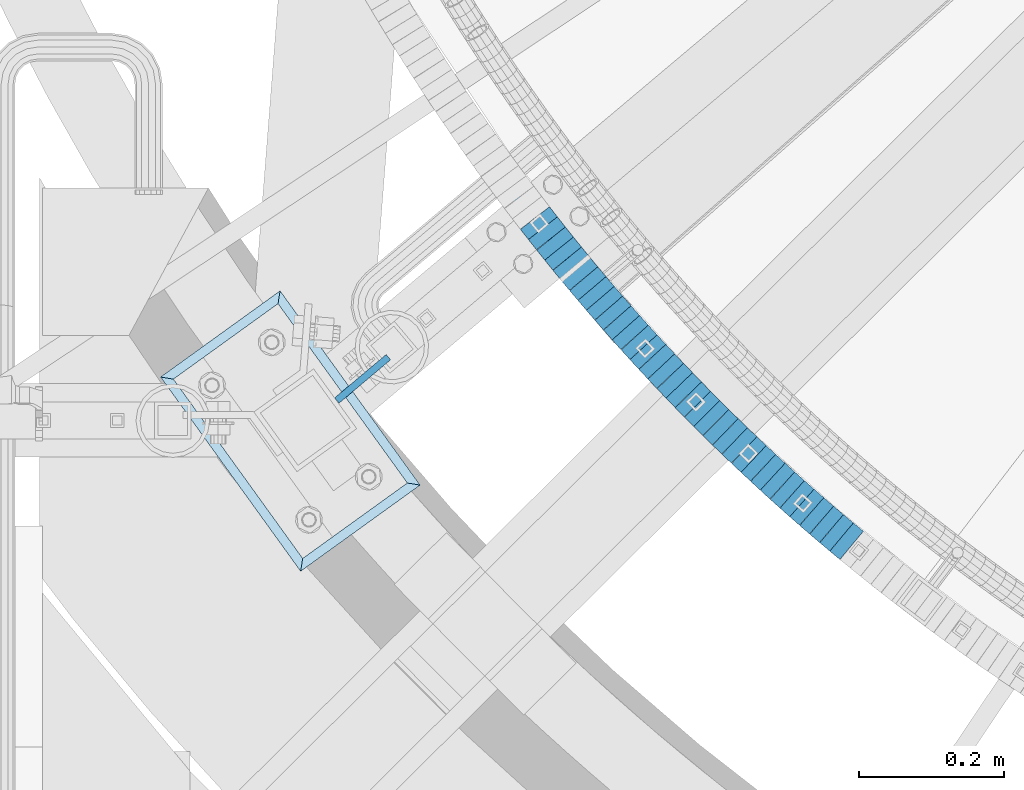
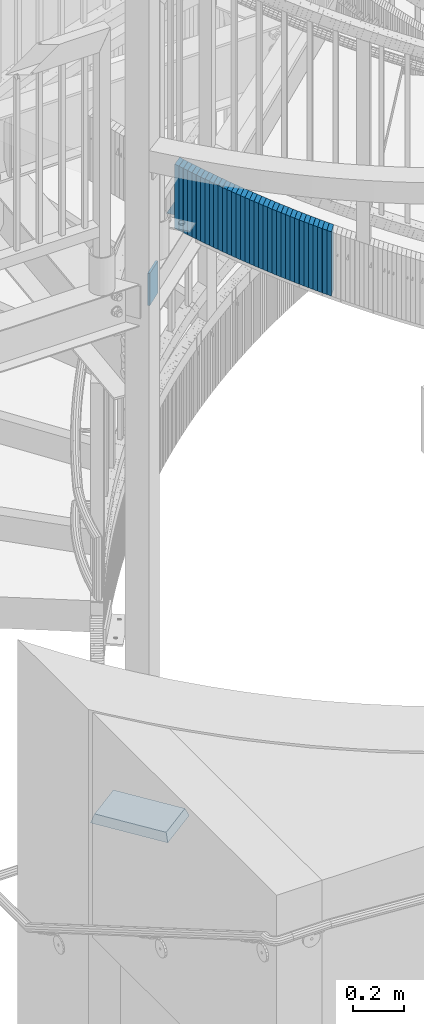
# One storey, part 875 of 975: 38 plates.
"""IFC2X3 building model written with IfcOpenShell, lengths in millimetres."""

from ifc_helpers import new_model, si_unit, frame, origin_with_axes, place, context, subcontext, project, spatial, faceted_brep, material, type_object, element, save


model = new_model("IFC2X3")

# Units and contexts
model_context = context("Model", 3, precision=1e-05, world=origin_with_axes())
body_context = subcontext(model_context, "Body", "Model", "MODEL_VIEW")
ifc_project = project(units=[si_unit("LENGTHUNIT", "METRE", prefix="MILLI"), si_unit("AREAUNIT", "SQUARE_METRE"), si_unit("VOLUMEUNIT", "CUBIC_METRE"), si_unit("MASSUNIT", "GRAM", prefix="KILO"), si_unit("TIMEUNIT", "SECOND"), si_unit("PLANEANGLEUNIT", "RADIAN"), si_unit("SOLIDANGLEUNIT", "STERADIAN"), si_unit("THERMODYNAMICTEMPERATUREUNIT", "DEGREE_CELSIUS"), si_unit("LUMINOUSINTENSITYUNIT", "LUMEN")], contexts=[model_context])

# Site, building, storey
site_placement = place(None, origin_with_axes())
site = spatial("IfcSite", under=ifc_project, at=site_placement, CompositionType="ELEMENT")
building_placement = place(site_placement, origin_with_axes())
building = spatial("IfcBuilding", under=site, at=building_placement, Name="Undefined", CompositionType="ELEMENT")
storey_placement = place(building_placement, origin_with_axes())
storey = spatial("IfcBuildingStorey", under=building, at=storey_placement, Name="Undefined", CompositionType="ELEMENT", Elevation=0.0)

# Plates
ifc_material_1 = material(Name="STEEL/A36")
plate_type_1 = type_object("IfcPlateType", PredefinedType="NOTDEFINED")
plate_1_placement = place(storey_placement, frame((32477.8496089641, 1629.99824004207, 3887.98750006769), z_axis=(-0.614330726999909, 0.789048640999883, 0.0), x_axis=(0.0, 0.0, 1.0)))
element("IfcPlate", 1, at=plate_1_placement, inside=storey, type_object=plate_type_1, material=ifc_material_1, Name="WALL", context=body_context, shape_type="Brep", body=[
    faceted_brep([(0.0, -25.3999999999724, -1.81898940354586e-11), (5.69999980926514, -25.3999999999833, 17.7428855895923), (5.69999980926514, 25.4000000000051, 17.7428855895996), (0.0, 25.3999999999869, 1.45519152283669e-11), (310.5, -25.3999999999833, 17.7428855895923), (310.5, 25.4000000000051, 17.7428855895996), (304.799987792969, -25.3999999999724, -1.81898940354586e-11), (304.799987792969, 25.3999999999869, 1.45519152283669e-11)], [[[0, 1, 2, 3]], [[1, 4, 5, 2]], [[4, 6, 7, 5]], [[6, 0, 3, 7]], [[5, 7, 3, 2]], [[6, 4, 1, 0]]]),
])
plate_2_placement = place(storey_placement, frame((32488.9189586468, 1615.90957309081, 3882.28750006769), z_axis=(-0.61782155188774, 0.786318338857122, 0.0), x_axis=(0.0, 0.0, 1.0)))
element("IfcPlate", 2, at=plate_2_placement, inside=storey, type_object=plate_type_1, material=ifc_material_1, Name="WALL", context=body_context, shape_type="Brep", body=[
    faceted_brep([(0.0, -25.3999999999724, -1.81898940354586e-11), (5.69999980926514, -25.4000000000196, 17.8002815246764), (5.69999980926514, 25.4000000000015, 17.8002815246618), (0.0, 25.3999999999869, 1.45519152283669e-11), (310.5, -25.4000000000196, 17.8002815246764), (310.5, 25.4000000000015, 17.8002815246618), (304.799987792969, -25.3999999999724, -1.81898940354586e-11), (304.799987792969, 25.3999999999869, 1.45519152283669e-11)], [[[0, 1, 2, 3]], [[1, 4, 5, 2]], [[4, 6, 7, 5]], [[6, 0, 3, 7]], [[5, 7, 3, 2]], [[6, 4, 1, 0]]]),
])
plate_3_placement = place(storey_placement, frame((32500.1994228176, 1601.88257092471, 3876.68750006769), z_axis=(-0.626758645080496, 0.779213450100074, 0.0), x_axis=(0.0, 0.0, 1.0)))
element("IfcPlate", 3, at=plate_3_placement, inside=storey, type_object=plate_type_1, material=ifc_material_1, Name="WALL", context=body_context, shape_type="Brep", body=[
    faceted_brep([(0.0, -25.3999999999724, -1.81898940354586e-11), (5.59999990463257, -25.4000000000087, 17.710166931156), (5.59999990463257, 25.399999999976, 17.7101669311705), (0.0, 25.3999999999869, 1.45519152283669e-11), (310.399993896484, -25.4000000000087, 17.710166931156), (310.399993896484, 25.399999999976, 17.7101669311705), (304.799987792969, -25.3999999999724, -1.81898940354586e-11), (304.799987792969, 25.3999999999869, 1.45519152283669e-11)], [[[0, 1, 2, 3]], [[1, 4, 5, 2]], [[4, 6, 7, 5]], [[6, 0, 3, 7]], [[5, 7, 3, 2]], [[6, 4, 1, 0]]]),
])
plate_4_placement = place(storey_placement, frame((32511.2994228141, 1588.08257092594, 3870.98750006769), z_axis=(-0.626758645080496, 0.779213450100074, 0.0), x_axis=(0.0, 0.0, 1.0)))
element("IfcPlate", 4, at=plate_4_placement, inside=storey, type_object=plate_type_1, material=ifc_material_1, Name="WALL", context=body_context, shape_type="Brep", body=[
    faceted_brep([(0.0, -25.3999999999724, -1.81898940354586e-11), (5.69999980926514, -25.3999999999978, 17.7101669311523), (5.69999980926514, 25.3999999999869, 17.7101669311669), (0.0, 25.3999999999869, 1.45519152283669e-11), (310.5, -25.3999999999978, 17.7101669311523), (310.5, 25.3999999999869, 17.7101669311669), (304.799987792969, -25.3999999999724, -1.81898940354586e-11), (304.799987792969, 25.3999999999869, 1.45519152283669e-11)], [[[0, 1, 2, 3]], [[1, 4, 5, 2]], [[4, 6, 7, 5]], [[6, 0, 3, 7]], [[5, 7, 3, 2]], [[6, 4, 1, 0]]]),
])
plate_5_placement = place(storey_placement, frame((32522.6265352931, 1574.22581840772, 3865.28750006769), z_axis=(-0.63293000409189, 0.774209022112401, 0.0), x_axis=(0.0, 0.0, 1.0)))
element("IfcPlate", 5, at=plate_5_placement, inside=storey, type_object=plate_type_1, material=ifc_material_1, Name="WALL", context=body_context, shape_type="Brep", body=[
    faceted_brep([(0.0, -25.3999999999724, -1.81898940354586e-11), (5.69999980926514, -25.3999999999724, 17.6954803466615), (5.69999980926514, 25.3999999999651, 17.6954803467124), (0.0, 25.3999999999869, 1.45519152283669e-11), (310.5, -25.3999999999724, 17.6954803466615), (310.5, 25.3999999999651, 17.6954803467124), (304.799987792969, -25.3999999999724, -1.81898940354586e-11), (304.799987792969, 25.3999999999869, 1.45519152283669e-11)], [[[0, 1, 2, 3]], [[1, 4, 5, 2]], [[4, 6, 7, 5]], [[6, 0, 3, 7]], [[5, 7, 3, 2]], [[6, 4, 1, 0]]]),
])
plate_6_placement = place(storey_placement, frame((32534.0550952989, 1560.46983275219, 3859.58750006769), z_axis=(-0.639071171629759, 0.769147604554397, 0.0), x_axis=(0.0, 0.0, 1.0)))
element("IfcPlate", 6, at=plate_6_placement, inside=storey, type_object=plate_type_1, material=ifc_material_1, Name="WALL", context=body_context, shape_type="Brep", body=[
    faceted_brep([(0.0, -25.3999999999724, -1.81898940354586e-11), (5.69999980926514, -25.4000000000124, 17.6819114685204), (5.69999980926514, 25.3999999999978, 17.6819114685022), (0.0, 25.3999999999869, 1.45519152283669e-11), (310.5, -25.4000000000124, 17.6819114685204), (310.5, 25.3999999999978, 17.6819114685022), (304.799987792969, -25.3999999999724, -1.81898940354586e-11), (304.799987792969, 25.3999999999869, 1.45519152283669e-11)], [[[0, 1, 2, 3]], [[1, 4, 5, 2]], [[4, 6, 7, 5]], [[6, 0, 3, 7]], [[5, 7, 3, 2]], [[6, 4, 1, 0]]]),
])
plate_7_placement = place(storey_placement, frame((32545.5850845881, 1546.81464773903, 3853.98750006769), z_axis=(-0.645180817852216, 0.764029915824993, 0.0), x_axis=(0.0, 0.0, 1.0)))
element("IfcPlate", 7, at=plate_7_placement, inside=storey, type_object=plate_type_1, material=ifc_material_1, Name="WALL", context=body_context, shape_type="Brep", body=[
    faceted_brep([(0.0, -25.3999999999724, -1.81898940354586e-11), (5.59999990463257, -25.4000000000451, 17.6694660187168), (5.59999990463257, 25.4000000000124, 17.6694660186622), (0.0, 25.3999999999869, 1.45519152283669e-11), (310.399993896484, -25.4000000000451, 17.6694660187168), (310.399993896484, 25.4000000000124, 17.6694660186622), (304.799987792969, -25.3999999999724, -1.81898940354586e-11), (304.799987792969, 25.3999999999869, 1.45519152283669e-11)], [[[0, 1, 2, 3]], [[1, 4, 5, 2]], [[4, 6, 7, 5]], [[6, 0, 3, 7]], [[5, 7, 3, 2]], [[6, 4, 1, 0]]]),
])
plate_8_placement = place(storey_placement, frame((32557.0453119958, 1533.34359052794, 3848.28750006769), z_axis=(-0.647978346010379, 0.761658757647842, 7.64916876505595e-11), x_axis=(0.0, 0.0, 1.0)))
element("IfcPlate", 8, at=plate_8_placement, inside=storey, type_object=plate_type_1, material=ifc_material_1, Name="WALL", context=body_context, shape_type="Brep", body=[
    faceted_brep([(0.0, -25.3999999999724, -1.81898940354586e-11), (5.69999980926514, -25.4000000000087, 17.5931797027697), (5.69999980926514, 25.4000000000124, 17.5931797027552), (0.0, 25.3999999999869, 1.45519152283669e-11), (310.5, -25.4000000000087, 17.5931797027697), (310.5, 25.4000000000124, 17.5931797027552), (304.799987792969, -25.3999999999724, -1.81898940354586e-11), (304.799987792969, 25.3999999999869, 1.45519152283669e-11)], [[[0, 1, 2, 3]], [[1, 4, 5, 2]], [[4, 6, 7, 5]], [[6, 0, 3, 7]], [[5, 7, 3, 2]], [[6, 4, 1, 0]]]),
])
plate_9_placement = place(storey_placement, frame((32568.6164840089, 1519.86029685642, 3842.68750006769), z_axis=(-0.651257624283248, 0.758856710330046, 0.0), x_axis=(0.0, 0.0, 1.0)))
element("IfcPlate", 9, at=plate_9_placement, inside=storey, type_object=plate_type_1, material=ifc_material_1, Name="WALL", context=body_context, shape_type="Brep", body=[
    faceted_brep([(0.0, -25.3999999999724, -1.81898940354586e-11), (5.59999990463257, -25.3999999999905, 17.6581420898401), (5.59999990463257, 25.4000000000196, 17.6581420898292), (0.0, 25.3999999999869, 1.45519152283669e-11), (310.399993896484, -25.3999999999905, 17.6581420898401), (310.399993896484, 25.4000000000196, 17.6581420898292), (304.799987792969, -25.3999999999724, -1.81898940354586e-11), (304.799987792969, 25.3999999999869, 1.45519152283669e-11)], [[[0, 1, 2, 3]], [[1, 4, 5, 2]], [[4, 6, 7, 5]], [[6, 0, 3, 7]], [[5, 7, 3, 2]], [[6, 4, 1, 0]]]),
])
plate_10_placement = place(storey_placement, frame((32580.3492735307, 1506.40681323147, 3836.98750006769), z_axis=(-0.657300286732873, 0.753628776693727, 0.0), x_axis=(0.0, 0.0, 1.0)))
element("IfcPlate", 10, at=plate_10_placement, inside=storey, type_object=plate_type_1, material=ifc_material_1, Name="WALL", context=body_context, shape_type="Brep", body=[
    faceted_brep([(0.0, -25.3999999999724, -1.81898940354586e-11), (5.69999980926514, -25.3999999999869, 17.6479454040382), (5.69999980926514, 25.3999999999651, 17.6479454040818), (0.0, 25.3999999999869, 1.45519152283669e-11), (310.5, -25.3999999999869, 17.6479454040382), (310.5, 25.3999999999651, 17.6479454040818), (304.799987792969, -25.3999999999724, -1.81898940354586e-11), (304.799987792969, 25.3999999999869, 1.45519152283669e-11)], [[[0, 1, 2, 3]], [[1, 4, 5, 2]], [[4, 6, 7, 5]], [[6, 0, 3, 7]], [[5, 7, 3, 2]], [[6, 4, 1, 0]]]),
])
plate_11_placement = place(storey_placement, frame((32592.3994301402, 1492.8361979417, 3831.18750006769), z_axis=(-0.66401742416183, 0.74771709918223, 0.0), x_axis=(0.0, 0.0, 1.0)))
element("IfcPlate", 11, at=plate_11_placement, inside=storey, type_object=plate_type_1, material=ifc_material_1, Name="WALL", context=body_context, shape_type="Brep", body=[
    faceted_brep([(0.0, -25.3999999999724, -1.81898940354586e-11), (5.80000019073486, -25.4000000000233, 17.9178676605334), (5.80000019073486, 25.3999999999942, 17.9178676605297), (0.0, 25.3999999999869, 1.45519152283669e-11), (310.600006103516, -25.4000000000233, 17.9178676605334), (310.600006103516, 25.3999999999942, 17.9178676605297), (304.799987792969, -25.3999999999724, -1.81898940354586e-11), (304.799987792969, 25.3999999999869, 1.45519152283669e-11)], [[[0, 1, 2, 3]], [[1, 4, 5, 2]], [[4, 6, 7, 5]], [[6, 0, 3, 7]], [[5, 7, 3, 2]], [[6, 4, 1, 0]]]),
])
plate_12_placement = place(storey_placement, frame((32604.2994301409, 1479.43619794325, 3825.48750006769), z_axis=(-0.66401742416183, 0.74771709918223, 0.0), x_axis=(0.0, 0.0, 1.0)))
element("IfcPlate", 12, at=plate_12_placement, inside=storey, type_object=plate_type_1, material=ifc_material_1, Name="WALL", context=body_context, shape_type="Brep", body=[
    faceted_brep([(0.0, -25.3999999999724, -1.81898940354586e-11), (5.69999980926514, -25.3999999999724, 17.9212169646999), (5.69999980926514, 25.3999999999651, 17.9212169647544), (0.0, 25.3999999999869, 1.45519152283669e-11), (310.5, -25.3999999999724, 17.9212169646999), (310.5, 25.3999999999651, 17.9212169647544), (304.799987792969, -25.3999999999724, -1.81898940354586e-11), (304.799987792969, 25.3999999999869, 1.45519152283669e-11)], [[[0, 1, 2, 3]], [[1, 4, 5, 2]], [[4, 6, 7, 5]], [[6, 0, 3, 7]], [[5, 7, 3, 2]], [[6, 4, 1, 0]]]),
])
plate_13_placement = place(storey_placement, frame((32616.6033599364, 1465.90932151631, 3819.78750006769), z_axis=(-0.672949566999793, 0.739688366999773, 0.0), x_axis=(0.0, 0.0, 1.0)))
element("IfcPlate", 13, at=plate_13_placement, inside=storey, type_object=plate_type_1, material=ifc_material_1, Name="WALL", context=body_context, shape_type="Brep", body=[
    faceted_brep([(0.0, -25.3999999999724, -1.81898940354586e-11), (5.69999980926514, -25.4000000000233, 17.9805450439708), (5.69999980926514, 25.4000000000124, 17.9805450439344), (0.0, 25.3999999999869, 1.45519152283669e-11), (310.5, -25.4000000000233, 17.9805450439708), (310.5, 25.4000000000124, 17.9805450439344), (304.799987792969, -25.3999999999724, -1.81898940354586e-11), (304.799987792969, 25.3999999999869, 1.45519152283669e-11)], [[[0, 1, 2, 3]], [[1, 4, 5, 2]], [[4, 6, 7, 5]], [[6, 0, 3, 7]], [[5, 7, 3, 2]], [[6, 4, 1, 0]]]),
])
plate_14_placement = place(storey_placement, frame((32628.767729298, 1452.6388349455, 3813.98750006769), z_axis=(-0.675724628879611, 0.737154139868665, 0.0), x_axis=(0.0, 0.0, 1.0)))
element("IfcPlate", 14, at=plate_14_placement, inside=storey, type_object=plate_type_1, material=ifc_material_1, Name="WALL", context=body_context, shape_type="Brep", body=[
    faceted_brep([(0.0, -25.3999999999724, -1.81898940354586e-11), (5.80000019073486, -25.3999999999905, 17.9067020416114), (5.80000019073486, 25.399999999976, 17.9067020416369), (0.0, 25.3999999999869, 1.45519152283669e-11), (310.600006103516, -25.3999999999905, 17.9067020416114), (310.600006103516, 25.399999999976, 17.9067020416369), (304.799987792969, -25.3999999999724, -1.81898940354586e-11), (304.799987792969, 25.3999999999869, 1.45519152283669e-11)], [[[0, 1, 2, 3]], [[1, 4, 5, 2]], [[4, 6, 7, 5]], [[6, 0, 3, 7]], [[5, 7, 3, 2]], [[6, 4, 1, 0]]]),
])
plate_15_placement = place(storey_placement, frame((32641.1037778449, 1439.39158916731, 3808.28750006769), z_axis=(-0.68152170678552, 0.7317978977697, 0.0), x_axis=(0.0, 0.0, 1.0)))
element("IfcPlate", 15, at=plate_15_placement, inside=storey, type_object=plate_type_1, material=ifc_material_1, Name="WALL", context=body_context, shape_type="Brep", body=[
    faceted_brep([(0.0, -25.3999999999724, -1.81898940354586e-11), (5.69999980926514, -25.3999999999978, 17.9011173248218), (5.69999980926514, 25.4000000000087, 17.9011173248182), (0.0, 25.3999999999869, 1.45519152283669e-11), (310.5, -25.3999999999978, 17.9011173248218), (310.5, 25.4000000000087, 17.9011173248182), (304.799987792969, -25.3999999999724, -1.81898940354586e-11), (304.799987792969, 25.3999999999869, 1.45519152283669e-11)], [[[0, 1, 2, 3]], [[1, 4, 5, 2]], [[4, 6, 7, 5]], [[6, 0, 3, 7]], [[5, 7, 3, 2]], [[6, 4, 1, 0]]]),
])
plate_16_placement = place(storey_placement, frame((32653.3700878644, 1426.32065973902, 3802.48750006769), z_axis=(-0.684314203948306, 0.729187266944916, 0.0), x_axis=(0.0, 0.0, 1.0)))
element("IfcPlate", 16, at=plate_16_placement, inside=storey, type_object=plate_type_1, material=ifc_material_1, Name="WALL", context=body_context, shape_type="Brep", body=[
    faceted_brep([(0.0, -25.3999999999724, -1.81898940354586e-11), (5.80000019073486, -25.3999999999796, 17.8280677795228), (5.80000019073486, 25.4000000000196, 17.8280677795265), (0.0, 25.3999999999869, 1.45519152283669e-11), (310.600006103516, -25.3999999999796, 17.8280677795228), (310.600006103516, 25.4000000000196, 17.8280677795265), (304.799987792969, -25.3999999999724, -1.81898940354586e-11), (304.799987792969, 25.3999999999869, 1.45519152283669e-11)], [[[0, 1, 2, 3]], [[1, 4, 5, 2]], [[4, 6, 7, 5]], [[6, 0, 3, 7]], [[5, 7, 3, 2]], [[6, 4, 1, 0]]]),
])
for number, where, z_axis, x_axis, name in (
    (17, (32665.9795570647, 1413.20011620637, 3796.78750006769), (-0.692997020245555, 0.720940448255458, 0.0), (0.0, 0.0, 1.0), "WALL"),
    (18, (32678.3795570702, 1400.30011620766, 3791.08750006769), (-0.692997020245555, 0.720940448255458, 0.0), (0.0, 0.0, 1.0), "WALL"),
):
    element("IfcPlate", number, at=place(storey_placement, frame(where, z_axis=z_axis, x_axis=x_axis)), inside=storey, type_object=plate_type_1, material=ifc_material_1, Name=name, context=body_context, shape_type="Brep", body=[
        faceted_brep([(0.0, -25.3999999999724, -1.81898940354586e-11), (5.69999980926514, -25.3999999999614, 17.8921775817616), (5.69999980926514, 25.400000000016, 17.8921775817726), (0.0, 25.3999999999869, 1.45519152283669e-11), (310.5, -25.3999999999614, 17.8921775817616), (310.5, 25.400000000016, 17.8921775817726), (304.799987792969, -25.3999999999724, -1.81898940354586e-11), (304.799987792969, 25.3999999999869, 1.45519152283669e-11)], [[[0, 1, 2, 3]], [[1, 4, 5, 2]], [[4, 6, 7, 5]], [[6, 0, 3, 7]], [[5, 7, 3, 2]], [[6, 4, 1, 0]]]),
    ])
plate_17_placement = place(storey_placement, frame((32691.0192392283, 1387.3559463482, 3785.28750006769), z_axis=(-0.698672998973499, 0.715441150972864, 0.0), x_axis=(0.0, 0.0, 1.0)))
element("IfcPlate", 19, at=plate_17_placement, inside=storey, type_object=plate_type_1, material=ifc_material_1, Name="WALL", context=body_context, shape_type="Brep", body=[
    faceted_brep([(0.0, -25.3999999999724, -1.81898940354586e-11), (5.80000019073486, -25.4000000000451, 17.8891029358201), (5.80000019073486, 25.4000000000087, 17.8891029357856), (0.0, 25.3999999999869, 1.45519152283669e-11), (310.600006103516, -25.4000000000451, 17.8891029358201), (310.600006103516, 25.4000000000087, 17.8891029357856), (304.799987792969, -25.3999999999724, -1.81898940354586e-11), (304.799987792969, 25.3999999999869, 1.45519152283669e-11)], [[[0, 1, 2, 3]], [[1, 4, 5, 2]], [[4, 6, 7, 5]], [[6, 0, 3, 7]], [[5, 7, 3, 2]], [[6, 4, 1, 0]]]),
])
for number, where, z_axis, x_axis, name in (
    (20, (32703.8309322206, 1374.54172828161, 3779.58750006769), (-0.707106781186601, 0.707106781186494, 2.36468622460961e-14), (0.0, 0.0, 1.0), "WALL"),
    (21, (32716.4309322205, 1361.94172828271, 3773.88750006769), (-0.707106781186601, 0.707106781186494, 2.36468622460961e-14), (0.0, 0.0, 1.0), "WALL"),
):
    element("IfcPlate", number, at=place(storey_placement, frame(where, z_axis=z_axis, x_axis=x_axis)), inside=storey, type_object=plate_type_1, material=ifc_material_1, Name=name, context=body_context, shape_type="Brep", body=[
        faceted_brep([(0.0, -25.3999999999724, -1.81898940354586e-11), (5.69999980926514, -25.3999999999432, 17.8213348388126), (5.69999980926514, 25.3999999999905, 17.8213348388708), (0.0, 25.3999999999869, 1.45519152283669e-11), (310.5, -25.3999999999432, 17.8213348388126), (310.5, 25.3999999999905, 17.8213348388708), (304.799987792969, -25.3999999999724, -1.81898940354586e-11), (304.799987792969, 25.3999999999869, 1.45519152283669e-11)], [[[0, 1, 2, 3]], [[1, 4, 5, 2]], [[4, 6, 7, 5]], [[6, 0, 3, 7]], [[5, 7, 3, 2]], [[6, 4, 1, 0]]]),
    ])
plate_18_placement = place(storey_placement, frame((32729.3729059506, 1349.20086805817, 3768.08750006769), z_axis=(-0.712652459353194, 0.701517264347674, 0.0), x_axis=(0.0, 0.0, 1.0)))
element("IfcPlate", 22, at=plate_18_placement, inside=storey, type_object=plate_type_1, material=ifc_material_1, Name="WALL", context=body_context, shape_type="Brep", body=[
    faceted_brep([(0.0, -25.3999999999724, -1.81898940354586e-11), (5.80000019073486, -25.399999999976, 17.9610691070338), (5.80000019073486, 25.4000000000269, 17.9610691070338), (0.0, 25.3999999999869, 1.45519152283669e-11), (310.600006103516, -25.399999999976, 17.9610691070338), (310.600006103516, 25.4000000000269, 17.9610691070338), (304.799987792969, -25.3999999999724, -1.81898940354586e-11), (304.799987792969, 25.3999999999869, 1.45519152283669e-11)], [[[0, 1, 2, 3]], [[1, 4, 5, 2]], [[4, 6, 7, 5]], [[6, 0, 3, 7]], [[5, 7, 3, 2]], [[6, 4, 1, 0]]]),
])
plate_19_placement = place(storey_placement, frame((32742.3182459892, 1336.65893886599, 3762.38750006769), z_axis=(-0.718240222804791, 0.695795215810891, 0.0), x_axis=(0.0, 0.0, 1.0)))
element("IfcPlate", 23, at=plate_19_placement, inside=storey, type_object=plate_type_1, material=ifc_material_1, Name="WALL", context=body_context, shape_type="Brep", body=[
    faceted_brep([(0.0, -25.3999999999724, -1.81898940354586e-11), (5.69999980926514, -25.3999999999432, 17.8213348388126), (5.69999980926514, 25.3999999999905, 17.8213348388708), (0.0, 25.3999999999869, 1.45519152283669e-11), (310.5, -25.3999999999432, 17.8213348388126), (310.5, 25.3999999999905, 17.8213348388708), (304.799987792969, -25.3999999999724, -1.81898940354586e-11), (304.799987792969, 25.3999999999869, 1.45519152283669e-11)], [[[0, 1, 2, 3]], [[1, 4, 5, 2]], [[4, 6, 7, 5]], [[6, 0, 3, 7]], [[5, 7, 3, 2]], [[6, 4, 1, 0]]]),
])
plate_20_placement = place(storey_placement, frame((32755.2893201537, 1324.19035313969, 3756.68750006769), z_axis=(-0.720940448255459, 0.692997020245555, 0.0), x_axis=(0.0, 0.0, 1.0)))
element("IfcPlate", 24, at=plate_20_placement, inside=storey, type_object=plate_type_1, material=ifc_material_1, Name="WALL", context=body_context, shape_type="Brep", body=[
    faceted_brep([(0.0, -25.3999999999724, -1.81898940354586e-11), (5.69999980926514, -25.3999999999614, 17.8921775817616), (5.69999980926514, 25.400000000016, 17.8921775817726), (0.0, 25.3999999999869, 1.45519152283669e-11), (310.5, -25.3999999999614, 17.8921775817616), (310.5, 25.400000000016, 17.8921775817726), (304.799987792969, -25.3999999999724, -1.81898940354586e-11), (304.799987792969, 25.3999999999869, 1.45519152283669e-11)], [[[0, 1, 2, 3]], [[1, 4, 5, 2]], [[4, 6, 7, 5]], [[6, 0, 3, 7]], [[5, 7, 3, 2]], [[6, 4, 1, 0]]]),
])
plate_21_placement = place(storey_placement, frame((32768.5098637013, 1311.78088394523, 3750.98750006769), z_axis=(-0.729187266944916, 0.684314203948306, 0.0), x_axis=(0.0, 0.0, 1.0)))
element("IfcPlate", 25, at=plate_21_placement, inside=storey, type_object=plate_type_1, material=ifc_material_1, Name="WALL", context=body_context, shape_type="Brep", body=[
    faceted_brep([(0.0, -25.3999999999724, -1.81898940354586e-11), (5.69999980926514, -25.3999999999724, 17.833955764745), (5.69999980926514, 25.3999999999905, 17.8339557647923), (0.0, 25.3999999999869, 1.45519152283669e-11), (310.5, -25.3999999999724, 17.833955764745), (310.5, 25.3999999999905, 17.8339557647923), (304.799987792969, -25.3999999999724, -1.81898940354586e-11), (304.799987792969, 25.3999999999869, 1.45519152283669e-11)], [[[0, 1, 2, 3]], [[1, 4, 5, 2]], [[4, 6, 7, 5]], [[6, 0, 3, 7]], [[5, 7, 3, 2]], [[6, 4, 1, 0]]]),
])
plate_22_placement = place(storey_placement, frame((32781.5098637152, 1299.58088394584, 3745.18750006769), z_axis=(-0.729187266944916, 0.684314203948306, 0.0), x_axis=(0.0, 0.0, 1.0)))
element("IfcPlate", 26, at=plate_22_placement, inside=storey, type_object=plate_type_1, material=ifc_material_1, Name="WALL", context=body_context, shape_type="Brep", body=[
    faceted_brep([(0.0, -25.3999999999724, -1.81898940354586e-11), (5.80000019073486, -25.3999999999796, 17.8280677795228), (5.80000019073486, 25.4000000000196, 17.8280677795265), (0.0, 25.3999999999869, 1.45519152283669e-11), (310.600006103516, -25.3999999999796, 17.8280677795228), (310.600006103516, 25.4000000000196, 17.8280677795265), (304.799987792969, -25.3999999999724, -1.81898940354586e-11), (304.799987792969, 25.3999999999869, 1.45519152283669e-11)], [[[0, 1, 2, 3]], [[1, 4, 5, 2]], [[4, 6, 7, 5]], [[6, 0, 3, 7]], [[5, 7, 3, 2]], [[6, 4, 1, 0]]]),
])
plate_23_placement = place(storey_placement, frame((32794.7572150542, 1287.3436946099, 3739.48750006769), z_axis=(-0.734588421928499, 0.678512969933956, 0.0), x_axis=(0.0, 0.0, 1.0)))
element("IfcPlate", 27, at=plate_23_placement, inside=storey, type_object=plate_type_1, material=ifc_material_1, Name="WALL", context=body_context, shape_type="Brep", body=[
    faceted_brep([(0.0, -25.3999999999724, -1.81898940354586e-11), (5.69999980926514, -25.3999999999724, 17.833955764745), (5.69999980926514, 25.3999999999905, 17.8339557647923), (0.0, 25.3999999999869, 1.45519152283669e-11), (310.5, -25.3999999999724, 17.833955764745), (310.5, 25.3999999999905, 17.8339557647923), (304.799987792969, -25.3999999999724, -1.81898940354586e-11), (304.799987792969, 25.3999999999869, 1.45519152283669e-11)], [[[0, 1, 2, 3]], [[1, 4, 5, 2]], [[4, 6, 7, 5]], [[6, 0, 3, 7]], [[5, 7, 3, 2]], [[6, 4, 1, 0]]]),
])
plate_24_placement = place(storey_placement, frame((32808.0280389353, 1275.17852536245, 3733.78750006769), z_axis=(-0.737154140366779, 0.675724628336214, 0.0), x_axis=(0.0, 0.0, 1.0)))
element("IfcPlate", 28, at=plate_24_placement, inside=storey, type_object=plate_type_1, material=ifc_material_1, Name="WALL", context=body_context, shape_type="Brep", body=[
    faceted_brep([(0.0, -25.3999999999724, -1.81898940354586e-11), (5.69999980926514, -25.4000000000633, 17.9075393677485), (5.69999980926514, 25.3999999999905, 17.9075393676903), (0.0, 25.3999999999869, 1.45519152283669e-11), (310.5, -25.4000000000633, 17.9075393677485), (310.5, 25.3999999999905, 17.9075393676903), (304.799987792969, -25.3999999999724, -1.81898940354586e-11), (304.799987792969, 25.3999999999869, 1.45519152283669e-11)], [[[0, 1, 2, 3]], [[1, 4, 5, 2]], [[4, 6, 7, 5]], [[6, 0, 3, 7]], [[5, 7, 3, 2]], [[6, 4, 1, 0]]]),
])
plate_25_placement = place(storey_placement, frame((32821.5548550646, 1263.07311115463, 3728.0875000677), z_axis=(-0.745241313969714, 0.666794858972904, 0.0), x_axis=(0.0, 0.0, 1.0)))
element("IfcPlate", 29, at=plate_25_placement, inside=storey, type_object=plate_type_1, material=ifc_material_1, Name="WALL", context=body_context, shape_type="Brep", body=[
    faceted_brep([(0.0, -25.3999999999724, -1.81898940354586e-11), (5.69999980926514, -25.4000000000196, 17.8538513183848), (5.69999980926514, 25.4000000000415, 17.8538513183157), (0.0, 25.3999999999869, 1.45519152283669e-11), (310.5, -25.4000000000196, 17.8538513183848), (310.5, 25.4000000000415, 17.8538513183157), (304.799987792969, -25.3999999999724, -1.81898940354586e-11), (304.799987792969, 25.3999999999869, 1.45519152283669e-11)], [[[0, 1, 2, 3]], [[1, 4, 5, 2]], [[4, 6, 7, 5]], [[6, 0, 3, 7]], [[5, 7, 3, 2]], [[6, 4, 1, 0]]]),
])
plate_26_placement = place(storey_placement, frame((32835.1050831394, 1251.13976239482, 3722.28750006769), z_axis=(-0.750491265131667, 0.660880368115947, 0.0), x_axis=(0.0, 0.0, 1.0)))
element("IfcPlate", 30, at=plate_26_placement, inside=storey, type_object=plate_type_1, material=ifc_material_1, Name="WALL", context=body_context, shape_type="Brep", body=[
    faceted_brep([(0.0, -25.3999999999724, -1.81898940354586e-11), (5.80000019073486, -25.4000000000306, 17.853010177645), (5.80000019073486, 25.3999999999578, 17.8530101776596), (0.0, 25.3999999999869, 1.45519152283669e-11), (310.600006103516, -25.4000000000306, 17.853010177645), (310.600006103516, 25.3999999999578, 17.8530101776596), (304.799987792969, -25.3999999999724, -1.81898940354586e-11), (304.799987792969, 25.3999999999869, 1.45519152283669e-11)], [[[0, 1, 2, 3]], [[1, 4, 5, 2]], [[4, 6, 7, 5]], [[6, 0, 3, 7]], [[5, 7, 3, 2]], [[6, 4, 1, 0]]]),
])
plate_27_placement = place(storey_placement, frame((32848.5050831464, 1239.33976239472, 3716.5875000677), z_axis=(-0.750491265131667, 0.660880368115947, 0.0), x_axis=(0.0, 0.0, 1.0)))
element("IfcPlate", 31, at=plate_27_placement, inside=storey, type_object=plate_type_1, material=ifc_material_1, Name="WALL", context=body_context, shape_type="Brep", body=[
    faceted_brep([(0.0, -25.3999999999724, -1.81898940354586e-11), (5.69999980926514, -25.4000000000196, 17.8538513183848), (5.69999980926514, 25.4000000000415, 17.8538513183157), (0.0, 25.3999999999869, 1.45519152283669e-11), (310.5, -25.4000000000196, 17.8538513183848), (310.5, 25.4000000000415, 17.8538513183157), (304.799987792969, -25.3999999999724, -1.81898940354586e-11), (304.799987792969, 25.3999999999869, 1.45519152283669e-11)], [[[0, 1, 2, 3]], [[1, 4, 5, 2]], [[4, 6, 7, 5]], [[6, 0, 3, 7]], [[5, 7, 3, 2]], [[6, 4, 1, 0]]]),
])
plate_28_placement = place(storey_placement, frame((32862.1562088297, 1227.50773781869, 3710.8875000677), z_axis=(-0.755689083086772, 0.654930538075203, 0.0), x_axis=(0.0, 0.0, 1.0)))
element("IfcPlate", 32, at=plate_28_placement, inside=storey, type_object=plate_type_1, material=ifc_material_1, Name="WALL", context=body_context, shape_type="Brep", body=[
    faceted_brep([(0.0, -25.3999999999724, -1.81898940354586e-11), (5.69999980926514, -25.4000000000378, 17.8639297485788), (5.69999980926514, 25.3999999999833, 17.8639297485533), (0.0, 25.3999999999869, 1.45519152283669e-11), (310.5, -25.4000000000378, 17.8639297485788), (310.5, 25.3999999999833, 17.8639297485533), (304.799987792969, -25.3999999999724, -1.81898940354586e-11), (304.799987792969, 25.3999999999869, 1.45519152283669e-11)], [[[0, 1, 2, 3]], [[1, 4, 5, 2]], [[4, 6, 7, 5]], [[6, 0, 3, 7]], [[5, 7, 3, 2]], [[6, 4, 1, 0]]]),
])
plate_29_placement = place(storey_placement, frame((32875.908200697, 1215.77705814754, 3705.0875000677), z_axis=(-0.760833952017173, 0.648946606014648, 0.0), x_axis=(0.0, 0.0, 1.0)))
element("IfcPlate", 33, at=plate_29_placement, inside=storey, type_object=plate_type_1, material=ifc_material_1, Name="WALL", context=body_context, shape_type="Brep", body=[
    faceted_brep([(0.0, -25.3999999999724, -1.81898940354586e-11), (5.80000019073486, -25.3999999999978, 17.8832321166956), (5.80000019073486, 25.4000000000415, 17.8832321166556), (0.0, 25.3999999999869, 1.45519152283669e-11), (310.600006103516, -25.3999999999978, 17.8832321166956), (310.600006103516, 25.4000000000415, 17.8832321166556), (304.799987792969, -25.3999999999724, -1.81898940354586e-11), (304.799987792969, 25.3999999999869, 1.45519152283669e-11)], [[[0, 1, 2, 3]], [[1, 4, 5, 2]], [[4, 6, 7, 5]], [[6, 0, 3, 7]], [[5, 7, 3, 2]], [[6, 4, 1, 0]]]),
])
plate_30_placement = place(storey_placement, frame((32889.7610270299, 1204.14774321596, 3699.3875000677), z_axis=(-0.765925091094036, 0.642929821078936, 0.0), x_axis=(0.0, 0.0, 1.0)))
element("IfcPlate", 34, at=plate_30_placement, inside=storey, type_object=plate_type_1, material=ifc_material_1, Name="WALL", context=body_context, shape_type="Brep", body=[
    faceted_brep([(0.0, -25.3999999999724, -1.81898940354586e-11), (5.69999980926514, -25.3999999999614, 17.8921775817616), (5.69999980926514, 25.400000000016, 17.8921775817726), (0.0, 25.3999999999869, 1.45519152283669e-11), (310.5, -25.3999999999614, 17.8921775817616), (310.5, 25.400000000016, 17.8921775817726), (304.799987792969, -25.3999999999724, -1.81898940354586e-11), (304.799987792969, 25.3999999999869, 1.45519152283669e-11)], [[[0, 1, 2, 3]], [[1, 4, 5, 2]], [[4, 6, 7, 5]], [[6, 0, 3, 7]], [[5, 7, 3, 2]], [[6, 4, 1, 0]]]),
])
plate_31_placement = place(storey_placement, frame((32903.630760728, 1192.58942002854, 3693.6875000677), z_axis=(-0.768221279597376, 0.64018439966448, 0.0), x_axis=(0.0, 0.0, 1.0)))
element("IfcPlate", 35, at=plate_31_placement, inside=storey, type_object=plate_type_1, material=ifc_material_1, Name="WALL", context=body_context, shape_type="Brep", body=[
    faceted_brep([(0.0, -25.3999999999724, -1.81898940354586e-11), (5.69999980926514, -25.400000000016, 17.9627399444762), (5.69999980926514, 25.3999999999869, 17.9627399444762), (0.0, 25.3999999999869, 1.45519152283669e-11), (310.5, -25.400000000016, 17.9627399444762), (310.5, 25.3999999999869, 17.9627399444762), (304.799987792969, -25.3999999999724, -1.81898940354586e-11), (304.799987792969, 25.3999999999869, 1.45519152283669e-11)], [[[0, 1, 2, 3]], [[1, 4, 5, 2]], [[4, 6, 7, 5]], [[6, 0, 3, 7]], [[5, 7, 3, 2]], [[6, 4, 1, 0]]]),
])
plate_type_2 = type_object("IfcPlateType", PredefinedType="NOTDEFINED")
plate_32_placement = place(storey_placement, frame((32193.7053461112, 1392.27501842702, 3911.6), z_axis=(0.76502246600244, 0.644003592002052, 0.0), x_axis=(0.0, 0.0, -1.0)))
element("IfcPlate", 36, at=plate_32_placement, inside=storey, type_object=plate_type_2, material=ifc_material_1, Name="PLATE", context=body_context, shape_type="Brep", body=[
    faceted_brep([(0.0, -4.76250000000073, 0.0), (0.0, -4.76250000002983, 92.9354629516893), (0.0, 4.76249999997162, 92.9354629516893), (0.0, 4.76250000000073, 0.0), (152.399993896484, -4.76250000002983, 92.9354629516893), (152.399993896484, 4.76249999997162, 92.9354629516893), (152.399993896484, -4.76250000000073, 0.0), (152.399993896484, 4.76250000000073, 0.0)], [[[0, 1, 2, 3]], [[1, 4, 5, 2]], [[4, 6, 7, 5]], [[6, 0, 3, 7]], [[5, 7, 3, 2]], [[6, 4, 1, 0]]]),
])
plate_type_3 = type_object("IfcPlateType", PredefinedType="NOTDEFINED")
plate_33_placement = place(storey_placement, frame((32487.5569034305, 1615.85806536616, 4089.39999765678), z_axis=(0.570963822494229, -0.678257323587103, -0.462566013022184), x_axis=(-0.297894173954409, 0.353873391945847, -0.886584842864326)))
element("IfcPlate", 37, at=plate_33_placement, inside=storey, type_object=plate_type_3, material=ifc_material_1, Name="PLATE", context=body_context, shape_type="Brep", body=[
    faceted_brep([(0.0, -4.76250000000073, 0.0), (-23.4983558654694, -4.76250000001164, 45.0385093688874), (-23.4983558654658, 4.7624999999789, 45.0385093688765), (0.0, 4.76250000000073, 0.0), (105.987365722634, -4.76249999985521, 112.596275329706), (105.98736572264, 4.76250000013533, 112.596275329697), (164.733245849568, -4.76249999980064, 2.16459739021957e-10), (164.733245849569, 4.7625000001899, 2.07364792004228e-10)], [[[0, 1, 2, 3]], [[1, 4, 5, 2]], [[4, 6, 7, 5]], [[6, 0, 3, 7]], [[5, 7, 3, 2]], [[6, 4, 1, 0]]]),
])
ifc_material_2 = material(Name="CONCRETE/GROUT")
plate_type_4 = type_object("IfcPlateType", PredefinedType="NOTDEFINED")
plate_34_placement = place(storey_placement, frame((32308.6329443945, 1275.6873915492, 1390.64999705358), z_axis=(-0.811165211384535, -0.58481706527724, 0.0), x_axis=(-0.584817058957379, 0.811165215940897, 0.0)))
element("IfcPlate", 38, at=plate_34_placement, inside=storey, type_object=plate_type_4, material=ifc_material_2, Name="GROUT", context=body_context, shape_type="Brep", body=[
    faceted_brep([(330.200012367033, 19.0500013667977, 203.199997417756), (1.09139364212751e-11, 19.05, 203.199996948282), (12.7000000020234, -19.0499999844749, 190.500000003405), (317.500000003602, -19.049999999379, 190.499999996773), (330.200012206657, 19.0500004884277, -1.48389517562464e-07), (317.499999999585, -19.0499999999586, 12.6999999966938), (12.6999999980108, -19.0499999989649, 12.7000000033258), (2.63382389675826e-07, 19.0500000000138, 0.0)], [[[0, 1, 2, 3]], [[4, 5, 6, 7]], [[5, 4, 0, 3]], [[6, 5, 3, 2]], [[7, 6, 2, 1]], [[4, 7, 1, 0]]]),
])

save(model, "model.ifc")
